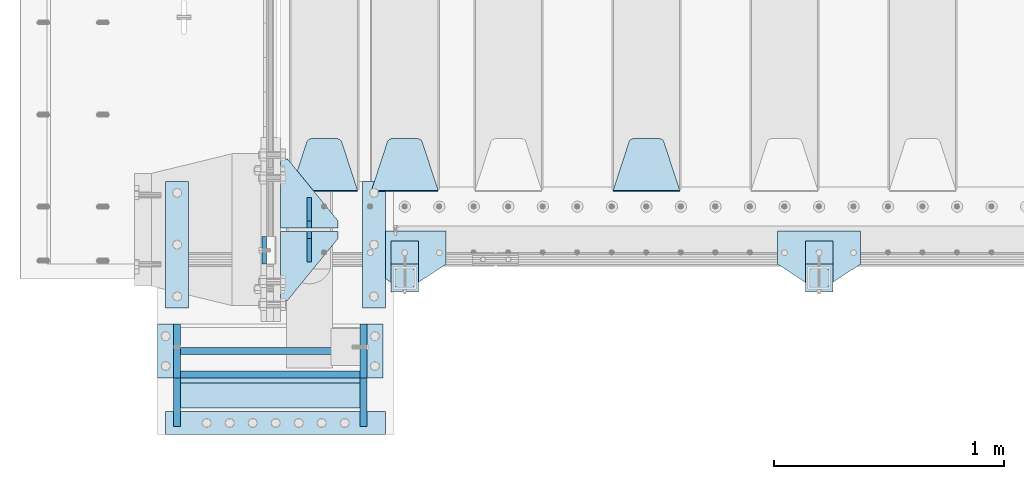
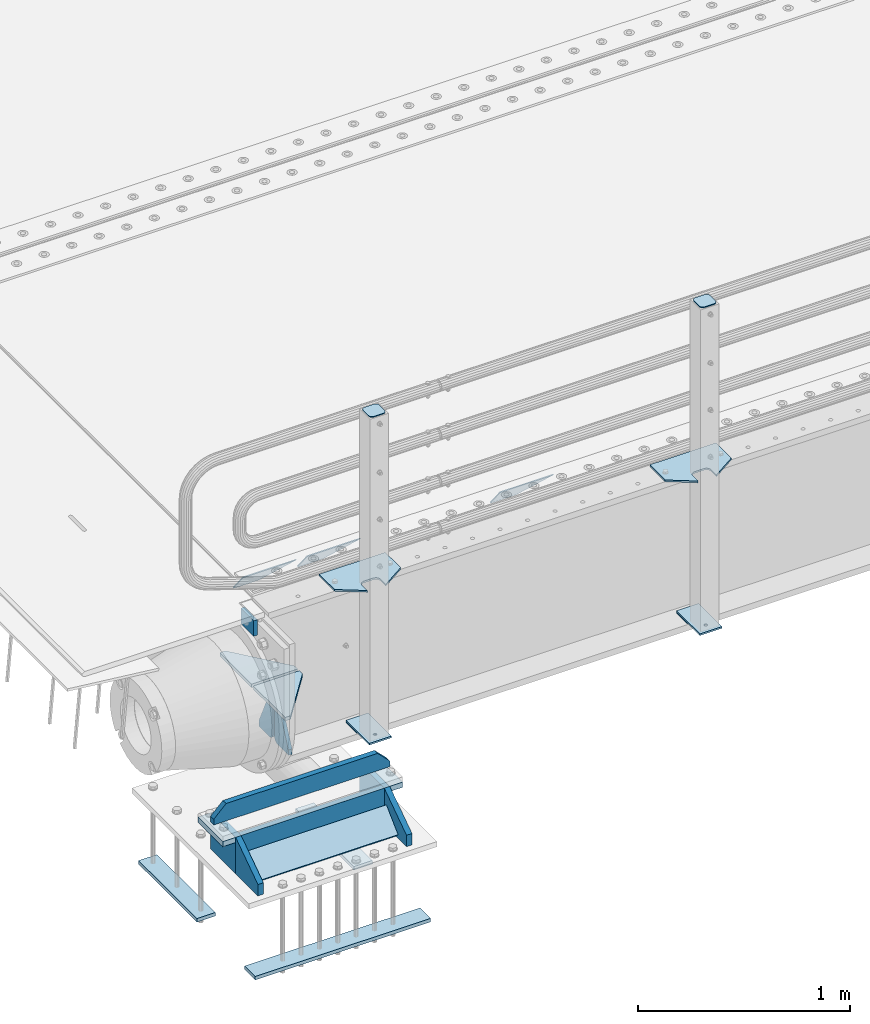
# One storey, part 214 of 270: 28 plates.
"""IFC2X3 building model written with IfcOpenShell, lengths in millimetres."""

from ifc_helpers import new_model, si_unit, frame, origin_with_axes, place, context, subcontext, project, spatial, faceted_brep, material, type_object, element, save


model = new_model("IFC2X3")

# Units and contexts
model_context = context("Model", 3, precision=1e-05, world=origin_with_axes())
body_context = subcontext(model_context, "Body", "Model", "MODEL_VIEW")
ifc_project = project(units=[si_unit("LENGTHUNIT", "METRE", prefix="MILLI"), si_unit("AREAUNIT", "SQUARE_METRE"), si_unit("VOLUMEUNIT", "CUBIC_METRE"), si_unit("MASSUNIT", "GRAM", prefix="KILO"), si_unit("TIMEUNIT", "SECOND"), si_unit("PLANEANGLEUNIT", "RADIAN"), si_unit("SOLIDANGLEUNIT", "STERADIAN"), si_unit("THERMODYNAMICTEMPERATUREUNIT", "DEGREE_CELSIUS"), si_unit("LUMINOUSINTENSITYUNIT", "LUMEN")], contexts=[model_context])

# Site, building, storey
site_placement = place(None, origin_with_axes())
site = spatial("IfcSite", under=ifc_project, at=site_placement, CompositionType="ELEMENT")
building_placement = place(site_placement, origin_with_axes())
building = spatial("IfcBuilding", under=site, at=building_placement, Name="Standard", CompositionType="ELEMENT")
storey_placement = place(building_placement, origin_with_axes())
storey = spatial("IfcBuildingStorey", under=building, at=storey_placement, Name="Undefined", CompositionType="ELEMENT", Elevation=0.0)

# Plates
ifc_material_1 = material(Name="STEEL/S355N")
plate_type_1 = type_object("IfcPlateType", PredefinedType="NOTDEFINED")
plate_1_placement = place(storey_placement, frame((-60.0000000000158, -24029.9995540187, -106.000105640918), z_axis=(0.0, -0.999999999987744, -4.95099999993769e-06), x_axis=(0.0, -4.95099997756316e-06, 0.999999999987744)))
element("IfcPlate", 1, at=plate_1_placement, inside=storey, type_object=plate_type_1, material=ifc_material_1, context=body_context, shape_type="Brep", body=[
    faceted_brep([(0.0, -10.0, 0.0), (4.30830482400779e-10, -10.0, 120.000000000004), (4.30830482400779e-10, 10.0, 120.000000000004), (0.0, 10.0, 0.0), (89.9999999999979, -10.0, 120.000000000004), (89.9999999999979, 10.0, 120.000000000004), (90.0, -10.0, 1.09139364212751e-11), (90.0, 10.0, 1.09139364212751e-11)], [[[0, 1, 2, 3]], [[1, 4, 5, 2]], [[4, 6, 7, 5]], [[6, 0, 3, 7]], [[5, 7, 3, 2]], [[6, 4, 1, 0]]]),
])
plate_type_2 = type_object("IfcPlateType", PredefinedType="NOTDEFINED")
plate_2_placement = place(storey_placement, frame((355.000000373937, -24765.3571373902, -1027.14966545662), z_axis=(-1.0, 0.0, 0.0), x_axis=(1.99999983730401e-09, 0.723355636225728, 0.690475650215467)))
element("IfcPlate", 2, at=plate_2_placement, inside=storey, type_object=plate_type_2, material=ifc_material_1, context=body_context, shape_type="Brep", body=[
    faceted_brep([(0.0, -15.0, 0.0), (2.15506588574499e-07, -15.0000000000018, 779.0), (2.15506588574499e-07, 14.9999999999982, 779.0), (0.0, 15.0, 0.0), (152.069061494802, -15.0000000000018, 779.0), (152.069061494802, 14.9999999999982, 779.0), (152.069061279297, -15.0000000000018, 0.0), (152.069061279299, 14.9999999999964, 0.0)], [[[0, 1, 2, 3]], [[1, 4, 5, 2]], [[4, 6, 7, 5]], [[6, 0, 3, 7]], [[5, 7, 3, 2]], [[6, 4, 1, 0]]]),
])
plate_type_3 = type_object("IfcPlateType", PredefinedType="NOTDEFINED")
for number, where, z_axis, x_axis in (
    (3, (366.000001649995, -24340.0000012037, -1478.0), (0.0, 1.0, 0.0), (1.0, 0.0, 0.0)),
    (4, (-488.999998350005, -24339.9999986388, -1478.0), (0.0, 1.0, 0.0), (1.0, 0.0, 0.0)),
):
    element("IfcPlate", number, at=place(storey_placement, frame(where, z_axis=z_axis, x_axis=x_axis)), inside=storey, type_object=plate_type_3, material=ifc_material_1, context=body_context, shape_type="Brep", body=[
        faceted_brep([(0.0, -10.0, 0.0), (1.00943600500614e-06, -10.0, 550.0), (1.00943600500614e-06, 10.0, 550.0), (0.0, 10.0, 0.0), (100.000000000004, -10.0, 550.0), (100.000000000004, 10.0, 550.0), (100.0, -10.0, 0.0), (100.0, 10.0, 0.0)], [[[0, 1, 2, 3]], [[1, 4, 5, 2]], [[4, 6, 7, 5]], [[6, 0, 3, 7]], [[5, 7, 3, 2]], [[6, 4, 1, 0]]]),
    ])
plate_3_placement = place(storey_placement, frame((-488.999999999989, -24889.9999986388, -1478.0), z_axis=(0.0, 1.0, 0.0), x_axis=(1.0, 0.0, 0.0)))
element("IfcPlate", 5, at=plate_3_placement, inside=storey, type_object=plate_type_3, material=ifc_material_1, context=body_context, shape_type="Brep", body=[
    faceted_brep([(0.0, -10.0, 0.0), (0.0, -10.0, 100.0), (0.0, 10.0, 100.0), (0.0, 10.0, 0.0), (955.0, -10.0, 100.0), (955.0, 10.0, 100.0), (955.0, -10.0, 0.0), (955.0, 10.0, 0.0)], [[[0, 1, 2, 3]], [[1, 4, 5, 2]], [[4, 6, 7, 5]], [[6, 0, 3, 7]], [[5, 7, 3, 2]], [[6, 4, 1, 0]]]),
])
plate_type_4 = type_object("IfcPlateType", PredefinedType="NOTDEFINED")
plate_4_placement = place(storey_placement, frame((370.000001439999, -24410.000002682, -828.000000000005), z_axis=(0.0, 0.0, -1.0), x_axis=(0.0, -1.0, 0.0)))
element("IfcPlate", 6, at=plate_4_placement, inside=storey, type_object=plate_type_4, material=ifc_material_1, context=body_context, shape_type="Brep", body=[
    faceted_brep([(0.0, -15.0, 0.0), (1.81898940354586e-12, -15.0, 210.0), (0.0, 15.0, 210.0), (0.0, 15.0, 0.0), (235.000000000002, -15.0, 210.0), (235.0, 15.0, 210.0), (235.0, -15.0, 0.0), (235.0, 15.0, 0.0)], [[[0, 1, 2, 3]], [[1, 4, 5, 2]], [[4, 6, 7, 5]], [[6, 0, 3, 7]], [[5, 7, 3, 2]], [[6, 4, 1, 0]]]),
])
for number, where, z_axis, x_axis in (
    (7, (370.00000010501, -24855.000002682, -1038.0), (0.0, 0.0, 1.0), (0.0, 1.0, 0.0)),
    (8, (-438.99999989499, -24855.000000255, -1038.0), (0.0, 0.0, 1.0), (0.0, 1.0, 0.0)),
):
    element("IfcPlate", number, at=place(storey_placement, frame(where, z_axis=z_axis, x_axis=x_axis)), inside=storey, type_object=plate_type_4, material=ifc_material_1, context=body_context, shape_type="Brep", body=[
        faceted_brep([(0.0, -15.0, 0.0), (-1.81898940354586e-12, -15.0, 66.0), (0.0, 15.0, 66.0), (0.0, 15.0, 0.0), (209.999999999998, -15.0, 210.0), (210.0, 15.0, 210.0), (209.999999999998, -15.0, 0.0), (210.0, 15.0, 0.0)], [[[0, 1, 2, 3]], [[1, 4, 5, 2]], [[4, 6, 7, 5]], [[6, 0, 3, 7]], [[5, 7, 3, 2]], [[6, 4, 1, 0]]]),
    ])
plate_5_placement = place(storey_placement, frame((-423.999999219995, -24630.0000003, -1038.0), z_axis=(1.0, 0.0, 0.0), x_axis=(0.0, 0.0, 1.0)))
element("IfcPlate", 9, at=plate_5_placement, inside=storey, type_object=plate_type_4, material=ifc_material_1, context=body_context, shape_type="Brep", body=[
    faceted_brep([(0.0, -15.0, 0.0), (2.15506588574499e-07, -15.0000000000018, 779.0), (2.15506588574499e-07, 14.9999999999982, 779.0), (0.0, 15.0, 0.0), (210.0, -15.0, 779.0), (210.0, 15.0, 779.0), (209.999999999998, -15.0, 0.0), (210.0, 15.0, 0.0)], [[[0, 1, 2, 3]], [[1, 4, 5, 2]], [[4, 6, 7, 5]], [[6, 0, 3, 7]], [[5, 7, 3, 2]], [[6, 4, 1, 0]]]),
])
plate_6_placement = place(storey_placement, frame((-438.999998560004, -24410.000000255, -828.000000000004), z_axis=(0.0, 0.0, -1.0), x_axis=(0.0, -1.0, 0.0)))
element("IfcPlate", 10, at=plate_6_placement, inside=storey, type_object=plate_type_4, material=ifc_material_1, context=body_context, shape_type="Brep", body=[
    faceted_brep([(0.0, -15.0, 0.0), (1.81898940354586e-12, -15.0, 210.0), (0.0, 15.0, 210.0), (0.0, 15.0, 0.0), (235.000000000002, -15.0, 210.0), (235.0, 15.0, 210.0), (235.0, -15.0, 0.0), (235.0, 15.0, 0.0)], [[[0, 1, 2, 3]], [[1, 4, 5, 2]], [[4, 6, 7, 5]], [[6, 0, 3, 7]], [[5, 7, 3, 2]], [[6, 4, 1, 0]]]),
])
plate_type_5 = type_object("IfcPlateType", PredefinedType="NOTDEFINED")
plate_7_placement = place(storey_placement, frame((-513.999998912499, -24527.50000003, -798.000000000004), z_axis=(0.0, 0.0, 1.0), x_axis=(1.0, 0.0, 0.0)))
element("IfcPlate", 11, at=plate_7_placement, inside=storey, type_object=plate_type_5, material=ifc_material_1, context=body_context, shape_type="Brep", body=[
    faceted_brep([(0.0, -15.0, 0.0), (-1.13686837721616e-13, -15.0, 33.0), (0.0, 15.0, 33.0), (0.0, 15.0, 0.0), (66.9999999999999, -15.0, 100.0), (66.9999999999999, 15.0, 100.0), (892.0, -15.0000000000018, 100.0), (892.0, 14.9999999999982, 100.0), (959.0, -15.0, 33.0), (959.0, 15.0, 33.0), (959.0, -15.0, 0.0), (959.0, 15.0, 0.0)], [[[0, 1, 2, 3]], [[1, 4, 5, 2]], [[4, 6, 7, 5]], [[6, 8, 9, 7]], [[8, 10, 11, 9]], [[10, 0, 3, 11]], [[5, 7, 9, 11, 3, 2]], [[10, 8, 6, 4, 1, 0]]]),
])
plate_type_6 = type_object("IfcPlateType", PredefinedType="NOTDEFINED")
for number, where, z_axis, x_axis in (
    (12, (385.000000735005, -24645.000002727, -843.000000000004), (1.0, 0.0, 0.0), (0.0, 1.0, 0.0)),
    (13, (-523.999999264995, -24645.0, -843.000000000004), (1.0, 0.0, 0.0), (0.0, 1.0, 0.0)),
):
    element("IfcPlate", number, at=place(storey_placement, frame(where, z_axis=z_axis, x_axis=x_axis)), inside=storey, type_object=plate_type_6, material=ifc_material_1, context=body_context, shape_type="Brep", body=[
        faceted_brep([(0.0, -15.0, 0.0), (0.0, -15.0, 70.0), (0.0, 15.0, 70.0), (0.0, 15.0, 0.0), (235.0, -15.0, 70.0), (235.0, 15.0, 70.0), (235.0, -15.0, 0.0), (235.0, 15.0, 0.0)], [[[0, 1, 2, 3]], [[1, 4, 5, 2]], [[4, 6, 7, 5]], [[6, 0, 3, 7]], [[5, 7, 3, 2]], [[6, 4, 1, 0]]]),
    ])
ifc_material_2 = material(Name="STEEL/S355J2")
plate_type_7 = type_object("IfcPlateType", PredefinedType="NOTDEFINED")
plate_8_placement = place(storey_placement, frame((2530.0, -24005.0, 5.00000000004911), z_axis=(0.0, -1.0, 0.0), x_axis=(-1.0, 0.0, 0.0)))
element("IfcPlate", 14, at=plate_8_placement, inside=storey, type_object=plate_type_7, material=ifc_material_2, context=body_context, shape_type="Brep", body=[
    faceted_brep([(0.0, -5.0, 0.0), (2.31396552408114e-06, -5.0, 145.0), (2.31396552408114e-06, 5.0, 145.0), (0.0, 5.0, 0.0), (130.0, -5.0, 230.0), (130.0, 5.0, 230.0), (130.0, -5.0, 180.0), (130.0, 5.0, 180.0), (130.48036798992, -5.0, 175.122741949597), (130.48036798992, 5.0, 175.122741949597), (131.903011687216, -5.0, 170.432914190873), (131.903011687216, 5.0, 170.432914190873), (134.213259692435, -5.0, 166.11074417451), (134.213259692435, 5.0, 166.11074417451), (137.322330470335, -5.0, 162.322330470337), (137.322330470335, 5.0, 162.322330470337), (141.110744174512, -5.0, 159.213259692437), (141.110744174512, 5.0, 159.213259692437), (145.432914190871, -5.0, 156.903011687218), (145.432914190871, 5.0, 156.903011687218), (150.122741949595, -5.0, 155.48036798992), (150.122741949595, 5.0, 155.48036798992), (155.0, -5.0, 155.0), (155.0, 5.0, 155.0), (205.0, -5.0, 155.0), (205.0, 5.0, 155.0), (209.877258050405, -5.0, 155.48036798992), (209.877258050405, 5.0, 155.48036798992), (214.567085809129, -5.0, 156.903011687218), (214.567085809129, 5.0, 156.903011687218), (218.889255825488, -5.0, 159.213259692437), (218.889255825488, 5.0, 159.213259692437), (222.677669529665, -5.0, 162.322330470337), (222.677669529665, 5.0, 162.322330470337), (225.786740307565, -5.0, 166.11074417451), (225.786740307565, 5.0, 166.11074417451), (228.096988312784, -5.0, 170.432914190873), (228.096988312784, 5.0, 170.432914190873), (229.51963201008, -5.0, 175.122741949597), (229.51963201008, 5.0, 175.122741949597), (230.0, -5.0, 180.0), (230.0, 5.0, 180.0), (230.0, -5.0, 230.0), (230.0, 5.0, 230.0), (360.0, -5.0, 145.0), (360.0, 5.0, 145.0), (360.0, -5.0, -7.27595761418343e-12), (360.0, 5.0, -7.27595761418343e-12)], [[[0, 1, 2, 3]], [[1, 4, 5, 2]], [[4, 6, 7, 5]], [[6, 8, 9, 7]], [[8, 10, 11, 9]], [[10, 12, 13, 11]], [[12, 14, 15, 13]], [[14, 16, 17, 15]], [[16, 18, 19, 17]], [[18, 20, 21, 19]], [[20, 22, 23, 21]], [[22, 24, 25, 23]], [[24, 26, 27, 25]], [[26, 28, 29, 27]], [[28, 30, 31, 29]], [[30, 32, 33, 31]], [[32, 34, 35, 33]], [[34, 36, 37, 35]], [[36, 38, 39, 37]], [[38, 40, 41, 39]], [[40, 42, 43, 41]], [[42, 44, 45, 43]], [[44, 46, 47, 45]], [[46, 0, 3, 47]], [[5, 7, 9, 11, 13, 15, 17, 19, 21, 23, 25, 27, 29, 31, 33, 35, 37, 39, 41, 43, 45, 47, 3, 2]], [[46, 44, 42, 40, 38, 36, 34, 32, 30, 28, 26, 24, 22, 20, 18, 16, 14, 12, 10, 8, 6, 4, 1, 0]]]),
])
plate_9_placement = place(storey_placement, frame((730.0, -24005.0, 5.00000000004911), z_axis=(0.0, -1.0, 0.0), x_axis=(-1.0, 0.0, 0.0)))
element("IfcPlate", 15, at=plate_9_placement, inside=storey, type_object=plate_type_7, material=ifc_material_2, context=body_context, shape_type="Brep", body=[
    faceted_brep([(0.0, -5.0, 0.0), (2.31396552408114e-06, -5.0, 145.0), (2.31396552408114e-06, 5.0, 145.0), (0.0, 5.0, 0.0), (130.0, -5.0, 230.0), (130.0, 5.0, 230.0), (130.0, -5.0, 180.0), (130.0, 5.0, 180.0), (130.48036798992, -5.0, 175.122741949597), (130.48036798992, 5.0, 175.122741949597), (131.903011687216, -5.0, 170.432914190873), (131.903011687216, 5.0, 170.432914190873), (134.213259692435, -5.0, 166.11074417451), (134.213259692435, 5.0, 166.11074417451), (137.322330470335, -5.0, 162.322330470337), (137.322330470335, 5.0, 162.322330470337), (141.110744174512, -5.0, 159.213259692437), (141.110744174512, 5.0, 159.213259692437), (145.432914190871, -5.0, 156.903011687218), (145.432914190871, 5.0, 156.903011687218), (150.122741949595, -5.0, 155.48036798992), (150.122741949595, 5.0, 155.48036798992), (155.0, -5.0, 155.0), (155.0, 5.0, 155.0), (205.0, -5.0, 155.0), (205.0, 5.0, 155.0), (209.877258050405, -5.0, 155.48036798992), (209.877258050405, 5.0, 155.48036798992), (214.567085809129, -5.0, 156.903011687218), (214.567085809129, 5.0, 156.903011687218), (218.889255825488, -5.0, 159.213259692437), (218.889255825488, 5.0, 159.213259692437), (222.677669529665, -5.0, 162.322330470337), (222.677669529665, 5.0, 162.322330470337), (225.786740307565, -5.0, 166.11074417451), (225.786740307565, 5.0, 166.11074417451), (228.096988312784, -5.0, 170.432914190873), (228.096988312784, 5.0, 170.432914190873), (229.51963201008, -5.0, 175.122741949597), (229.51963201008, 5.0, 175.122741949597), (230.0, -5.0, 180.0), (230.0, 5.0, 180.0), (230.0, -5.0, 230.0), (230.0, 5.0, 230.0), (360.0, -5.0, 145.0), (360.0, 5.0, 145.0), (360.0, -5.0, -7.27595761418343e-12), (360.0, 5.0, -7.27595761418343e-12)], [[[0, 1, 2, 3]], [[1, 4, 5, 2]], [[4, 6, 7, 5]], [[6, 8, 9, 7]], [[8, 10, 11, 9]], [[10, 12, 13, 11]], [[12, 14, 15, 13]], [[14, 16, 17, 15]], [[16, 18, 19, 17]], [[18, 20, 21, 19]], [[20, 22, 23, 21]], [[22, 24, 25, 23]], [[24, 26, 27, 25]], [[26, 28, 29, 27]], [[28, 30, 31, 29]], [[30, 32, 33, 31]], [[32, 34, 35, 33]], [[34, 36, 37, 35]], [[36, 38, 39, 37]], [[38, 40, 41, 39]], [[40, 42, 43, 41]], [[42, 44, 45, 43]], [[44, 46, 47, 45]], [[46, 0, 3, 47]], [[5, 7, 9, 11, 13, 15, 17, 19, 21, 23, 25, 27, 29, 31, 33, 35, 37, 39, 41, 43, 45, 47, 3, 2]], [[46, 44, 42, 40, 38, 36, 34, 32, 30, 28, 26, 24, 22, 20, 18, 16, 14, 12, 10, 8, 6, 4, 1, 0]]]),
])
plate_type_8 = type_object("IfcPlateType", PredefinedType="NOTDEFINED")
for number, where, z_axis, x_axis in (
    (16, (2409.99999999986, -24050.0000000002, -850.000000000002), (0.0, -1.0, 0.0), (-1.0, 0.0, 0.0)),
    (17, (609.999999999862, -24050.0000000002, -850.000000000002), (0.0, -1.0, 0.0), (-1.0, 0.0, 0.0)),
):
    element("IfcPlate", number, at=place(storey_placement, frame(where, z_axis=z_axis, x_axis=x_axis)), inside=storey, type_object=plate_type_8, material=ifc_material_2, context=body_context, shape_type="Brep", body=[
        faceted_brep([(53.6360389691836, -5.0, 176.363961030471), (53.6360389691836, 5.0, 176.363961030471), (59.9999999998618, 5.0, 178.999999999793), (59.9999999998618, -5.0, 178.999999999793), (66.3639610305399, 5.0, 176.363961030471), (66.3639610305399, -5.0, 176.363961030471), (68.9999999998618, 5.0, 169.999999999793), (68.9999999998618, -5.0, 169.999999999793), (66.3639610305399, 5.0, 163.636038969114), (66.3639610305399, -5.0, 163.636038969114), (59.9999999998618, 5.0, 160.999999999793), (59.9999999998618, -5.0, 160.999999999793), (53.6360389691836, 5.0, 163.636038969114), (53.6360389691836, -5.0, 163.636038969114), (50.9999999998618, 5.0, 169.999999999793), (50.9999999998618, -5.0, 169.999999999793), (120.0, -5.0, 0.0), (120.0, -5.0, 220.0), (0.0, -5.0, 220.0), (0.0, -5.0, 0.0), (0.0, 5.0, 0.0), (120.0, 5.0, 0.0), (120.0, 5.0, 220.0), (0.0, 5.0, 220.0)], [[[0, 1, 2, 3]], [[3, 2, 4, 5]], [[5, 4, 6, 7]], [[7, 6, 8, 9]], [[9, 8, 10, 11]], [[11, 10, 12, 13]], [[13, 12, 14, 15]], [[15, 14, 1, 0]], [[16, 17, 18, 19], [11, 13, 15, 0, 3, 5, 7, 9]], [[16, 19, 20, 21]], [[17, 16, 21, 22]], [[18, 17, 22, 23]], [[19, 18, 23, 20]], [[22, 21, 20, 23], [2, 1, 14, 12, 10, 8, 6, 4]]]),
    ])
plate_type_9 = type_object("IfcPlateType", PredefinedType="NOTDEFINED")
plate_10_placement = place(storey_placement, frame((2305.99999999987, -24166.0000000002, 1012.50000000001), z_axis=(0.0, -1.0, 0.0), x_axis=(1.0, 0.0, 0.0)))
element("IfcPlate", 18, at=plate_10_placement, inside=storey, type_object=plate_type_9, material=ifc_material_2, context=body_context, shape_type="Brep", body=[
    faceted_brep([(0.0, -2.5, 19.0), (0.0, -2.5, 69.0), (0.0, 2.5, 69.0), (0.0, 2.5, 19.0), (0.476369668544066, -2.5, 73.2278977451697), (0.476369668544066, 2.5, 73.2278977451697), (1.88159150985302, -2.5, 77.2437910432327), (1.88159150985302, 2.5, 77.2437910432327), (4.14520183310742, -2.5, 80.8463062353167), (4.14520183310742, 2.5, 80.8463062353167), (7.15369376468516, -2.5, 83.8547981668926), (7.15369376468516, 2.5, 83.8547981668926), (10.7562089567655, -2.5, 86.1184084901452), (10.7562089567655, 2.5, 86.1184084901452), (14.7721022548285, -2.5, 87.5236303314541), (14.7721022548285, 2.5, 87.5236303314541), (19.0, -2.5, 88.0), (19.0, 2.5, 88.0), (69.0, -2.5, 88.0), (69.0, 2.5, 88.0), (73.2278977451715, -2.5, 87.5236303314541), (73.2278977451715, 2.5, 87.5236303314541), (77.2437910432345, -2.5, 86.1184084901452), (77.2437910432345, 2.5, 86.1184084901452), (80.8463062353148, -2.5, 83.8547981668926), (80.8463062353148, 2.5, 83.8547981668926), (83.8547981668926, -2.5, 80.8463062353167), (83.8547981668926, 2.5, 80.8463062353167), (86.118408490147, -2.5, 77.2437910432345), (86.118408490147, 2.5, 77.2437910432345), (87.5236303314559, -2.5, 73.2278977451697), (87.5236303314559, 2.5, 73.2278977451697), (88.0, -2.5, 69.0), (88.0, 2.5, 69.0), (88.0, -2.5, 19.0), (88.0, 2.5, 19.0), (87.5236303314559, -2.5, 14.7721022548303), (87.5236303314559, 2.5, 14.7721022548303), (86.118408490147, -2.5, 10.7562089567673), (86.118408490147, 2.5, 10.7562089567673), (83.8547981668926, -2.5, 7.15369376468334), (83.8547981668926, 2.5, 7.15369376468334), (80.8463062353148, -2.5, 4.14520183310742), (80.8463062353148, 2.5, 4.14520183310742), (77.2437910432345, -2.5, 1.88159150985484), (77.2437910432345, 2.5, 1.88159150985484), (73.2278977451715, -2.5, 0.476369668545885), (73.2278977451715, 2.5, 0.476369668545885), (69.0, -2.5, 0.0), (69.0, 2.5, 0.0), (19.0, -2.5, 0.0), (19.0, 2.5, 0.0), (14.7721022548285, -2.5, 0.476369668545885), (14.7721022548285, 2.5, 0.476369668545885), (10.7562089567655, -2.5, 1.88159150985484), (10.7562089567655, 2.5, 1.88159150985484), (7.15369376468516, -2.5, 4.14520183310742), (7.15369376468516, 2.5, 4.14520183310742), (4.14520183310742, -2.5, 7.15369376468334), (4.14520183310742, 2.5, 7.15369376468334), (1.88159150985302, -2.5, 10.7562089567673), (1.88159150985302, 2.5, 10.7562089567673), (0.476369668544066, -2.5, 14.7721022548303), (0.476369668544066, 2.5, 14.7721022548303)], [[[0, 1, 2, 3]], [[1, 4, 5, 2]], [[4, 6, 7, 5]], [[6, 8, 9, 7]], [[8, 10, 11, 9]], [[10, 12, 13, 11]], [[12, 14, 15, 13]], [[14, 16, 17, 15]], [[16, 18, 19, 17]], [[18, 20, 21, 19]], [[20, 22, 23, 21]], [[22, 24, 25, 23]], [[24, 26, 27, 25]], [[26, 28, 29, 27]], [[28, 30, 31, 29]], [[30, 32, 33, 31]], [[32, 34, 35, 33]], [[34, 36, 37, 35]], [[36, 38, 39, 37]], [[38, 40, 41, 39]], [[40, 42, 43, 41]], [[42, 44, 45, 43]], [[44, 46, 47, 45]], [[46, 48, 49, 47]], [[48, 50, 51, 49]], [[50, 52, 53, 51]], [[52, 54, 55, 53]], [[54, 56, 57, 55]], [[56, 58, 59, 57]], [[58, 60, 61, 59]], [[60, 62, 63, 61]], [[62, 0, 3, 63]], [[5, 7, 9, 11, 13, 15, 17, 19, 21, 23, 25, 27, 29, 31, 33, 35, 37, 39, 41, 43, 45, 47, 49, 51, 53, 55, 57, 59, 61, 63, 3, 2]], [[62, 60, 58, 56, 54, 52, 50, 48, 46, 44, 42, 40, 38, 36, 34, 32, 30, 28, 26, 24, 22, 20, 18, 16, 14, 12, 10, 8, 6, 4, 1, 0]]]),
])
plate_11_placement = place(storey_placement, frame((505.999999999869, -24166.0000000002, 1012.50000000001), z_axis=(0.0, -1.0, 0.0), x_axis=(1.0, 0.0, 0.0)))
element("IfcPlate", 19, at=plate_11_placement, inside=storey, type_object=plate_type_9, material=ifc_material_2, context=body_context, shape_type="Brep", body=[
    faceted_brep([(0.0, -2.5, 19.0), (0.0, -2.5, 69.0), (0.0, 2.5, 69.0), (0.0, 2.5, 19.0), (0.476369668544066, -2.5, 73.2278977451697), (0.476369668544066, 2.5, 73.2278977451697), (1.88159150985302, -2.5, 77.2437910432327), (1.88159150985302, 2.5, 77.2437910432327), (4.14520183310742, -2.5, 80.8463062353167), (4.14520183310742, 2.5, 80.8463062353167), (7.15369376468516, -2.5, 83.8547981668926), (7.15369376468516, 2.5, 83.8547981668926), (10.7562089567655, -2.5, 86.1184084901452), (10.7562089567655, 2.5, 86.1184084901452), (14.7721022548285, -2.5, 87.5236303314541), (14.7721022548285, 2.5, 87.5236303314541), (19.0, -2.5, 88.0), (19.0, 2.5, 88.0), (69.0, -2.5, 88.0), (69.0, 2.5, 88.0), (73.2278977451715, -2.5, 87.5236303314541), (73.2278977451715, 2.5, 87.5236303314541), (77.2437910432345, -2.5, 86.1184084901452), (77.2437910432345, 2.5, 86.1184084901452), (80.8463062353148, -2.5, 83.8547981668926), (80.8463062353148, 2.5, 83.8547981668926), (83.8547981668926, -2.5, 80.8463062353167), (83.8547981668926, 2.5, 80.8463062353167), (86.118408490147, -2.5, 77.2437910432345), (86.118408490147, 2.5, 77.2437910432345), (87.5236303314559, -2.5, 73.2278977451697), (87.5236303314559, 2.5, 73.2278977451697), (88.0, -2.5, 69.0), (88.0, 2.5, 69.0), (88.0, -2.5, 19.0), (88.0, 2.5, 19.0), (87.5236303314559, -2.5, 14.7721022548303), (87.5236303314559, 2.5, 14.7721022548303), (86.118408490147, -2.5, 10.7562089567673), (86.118408490147, 2.5, 10.7562089567673), (83.8547981668926, -2.5, 7.15369376468334), (83.8547981668926, 2.5, 7.15369376468334), (80.8463062353148, -2.5, 4.14520183310742), (80.8463062353148, 2.5, 4.14520183310742), (77.2437910432345, -2.5, 1.88159150985484), (77.2437910432345, 2.5, 1.88159150985484), (73.2278977451715, -2.5, 0.476369668545885), (73.2278977451715, 2.5, 0.476369668545885), (69.0, -2.5, 0.0), (69.0, 2.5, 0.0), (19.0, -2.5, 0.0), (19.0, 2.5, 0.0), (14.7721022548285, -2.5, 0.476369668545885), (14.7721022548285, 2.5, 0.476369668545885), (10.7562089567655, -2.5, 1.88159150985484), (10.7562089567655, 2.5, 1.88159150985484), (7.15369376468516, -2.5, 4.14520183310742), (7.15369376468516, 2.5, 4.14520183310742), (4.14520183310742, -2.5, 7.15369376468334), (4.14520183310742, 2.5, 7.15369376468334), (1.88159150985302, -2.5, 10.7562089567673), (1.88159150985302, 2.5, 10.7562089567673), (0.476369668544066, -2.5, 14.7721022548303), (0.476369668544066, 2.5, 14.7721022548303)], [[[0, 1, 2, 3]], [[1, 4, 5, 2]], [[4, 6, 7, 5]], [[6, 8, 9, 7]], [[8, 10, 11, 9]], [[10, 12, 13, 11]], [[12, 14, 15, 13]], [[14, 16, 17, 15]], [[16, 18, 19, 17]], [[18, 20, 21, 19]], [[20, 22, 23, 21]], [[22, 24, 25, 23]], [[24, 26, 27, 25]], [[26, 28, 29, 27]], [[28, 30, 31, 29]], [[30, 32, 33, 31]], [[32, 34, 35, 33]], [[34, 36, 37, 35]], [[36, 38, 39, 37]], [[38, 40, 41, 39]], [[40, 42, 43, 41]], [[42, 44, 45, 43]], [[44, 46, 47, 45]], [[46, 48, 49, 47]], [[48, 50, 51, 49]], [[50, 52, 53, 51]], [[52, 54, 55, 53]], [[54, 56, 57, 55]], [[56, 58, 59, 57]], [[58, 60, 61, 59]], [[60, 62, 63, 61]], [[62, 0, 3, 63]], [[5, 7, 9, 11, 13, 15, 17, 19, 21, 23, 25, 27, 29, 31, 33, 35, 37, 39, 41, 43, 45, 47, 49, 51, 53, 55, 57, 59, 61, 63, 3, 2]], [[62, 60, 58, 56, 54, 52, 50, 48, 46, 44, 42, 40, 38, 36, 34, 32, 30, 28, 26, 24, 22, 20, 18, 16, 14, 12, 10, 8, 6, 4, 1, 0]]]),
])
plate_type_10 = type_object("IfcPlateType", PredefinedType="NOTDEFINED")
for number, where, z_axis, x_axis in (
    (20, (2409.99999999986, -24050.0000000002, -857.500000000002), (0.0, -1.0, 0.0), (-1.0, 0.0, 0.0)),
    (21, (609.999999999862, -24050.0000000002, -857.500000000002), (0.0, -1.0, 0.0), (-1.0, 0.0, 0.0)),
):
    element("IfcPlate", number, at=place(storey_placement, frame(where, z_axis=z_axis, x_axis=x_axis)), inside=storey, type_object=plate_type_10, material=ifc_material_2, context=body_context, shape_type="Brep", body=[
        faceted_brep([(0.0, -2.5, 0.0), (0.0, -2.5, 100.0), (0.0, 2.5, 100.0), (0.0, 2.5, 0.0), (120.0, -2.5, 100.0), (120.0, 2.5, 100.0), (120.0, -2.5, 0.0), (120.0, 2.5, 0.0)], [[[0, 1, 2, 3]], [[1, 4, 5, 2]], [[4, 6, 7, 5]], [[6, 0, 3, 7]], [[5, 7, 3, 2]], [[6, 4, 1, 0]]]),
    ])
plate_type_11 = type_object("IfcPlateType", PredefinedType="NOTDEFINED")
plate_12_placement = place(storey_placement, frame((1745.0, -23831.767766953, -1.76776695296758), z_axis=(0.0, 0.707106781186547, -0.707106781186548), x_axis=(-1.0, 0.0, 0.0)))
element("IfcPlate", 22, at=plate_12_placement, inside=storey, type_object=plate_type_11, material=ifc_material_1, context=body_context, shape_type="Brep", body=[
    faceted_brep([(0.0, -2.5, 0.0), (69.345504679477, -2.5, 300.171731424831), (69.345504679477, 2.5, 300.171731424831), (0.0, 2.5, 0.0), (70.9274061199576, -2.5, 304.8974424154), (70.9274061199576, 2.5, 304.8974424154), (73.3818627772307, -2.49999999999818, 309.234538108527), (73.3818627772307, 2.50000000000182, 309.234538108527), (76.6187032999551, -2.5, 313.023683126103), (76.6187032999551, 2.5, 313.023683126103), (80.5190132704993, -2.5, 316.125672595372), (80.5190132704993, 2.50000000000182, 316.125672595372), (84.9395038596849, -2.49999999999818, 318.426546230476), (84.9395038596849, 2.5, 318.426546230476), (89.7177759439219, -2.49999999999818, 319.841774983275), (89.7177759439219, 2.50000000000182, 319.841774983275), (94.678286292652, -2.5, 320.319366455078), (94.678286292652, 2.5, 320.319366455078), (195.321713707348, -2.5, 320.319366455078), (195.321713707348, 2.5, 320.319366455078), (200.282224056078, -2.49999999999818, 319.841774983275), (200.282224056078, 2.50000000000182, 319.841774983275), (205.060496140315, -2.5, 318.426546230476), (205.060496140315, 2.5, 318.426546230476), (209.480986729501, -2.5, 316.12567259537), (209.480986729501, 2.50000000000182, 316.12567259537), (213.381296700045, -2.5, 313.023683126103), (213.381296700045, 2.5, 313.023683126103), (216.618137222769, -2.49999999999818, 309.234538108525), (216.618137222769, 2.50000000000182, 309.234538108527), (219.072593880042, -2.49999999999818, 304.897442415398), (219.072593880042, 2.50000000000182, 304.897442415397), (220.654495320523, -2.5, 300.171731424831), (220.654495320523, 2.5, 300.171731424831), (290.0, -2.49999999999818, 0.0), (290.0, 2.5, 0.0)], [[[0, 1, 2, 3]], [[1, 4, 5, 2]], [[4, 6, 7, 5]], [[6, 8, 9, 7]], [[8, 10, 11, 9]], [[10, 12, 13, 11]], [[12, 14, 15, 13]], [[14, 16, 17, 15]], [[16, 18, 19, 17]], [[18, 20, 21, 19]], [[20, 22, 23, 21]], [[22, 24, 25, 23]], [[24, 26, 27, 25]], [[26, 28, 29, 27]], [[28, 30, 31, 29]], [[30, 32, 33, 31]], [[32, 34, 35, 33]], [[34, 0, 3, 35]], [[5, 7, 9, 11, 13, 15, 17, 19, 21, 23, 25, 27, 29, 31, 33, 35, 3, 2]], [[34, 32, 30, 28, 26, 24, 22, 20, 18, 16, 14, 12, 10, 8, 6, 4, 1, 0]]]),
])
plate_13_placement = place(storey_placement, frame((695.0, -23831.767766953, -1.76776695296758), z_axis=(0.0, 0.707106781186547, -0.707106781186548), x_axis=(-1.0, 0.0, 0.0)))
element("IfcPlate", 23, at=plate_13_placement, inside=storey, type_object=plate_type_11, material=ifc_material_1, context=body_context, shape_type="Brep", body=[
    faceted_brep([(0.0, -2.5, 0.0), (69.345504679477, -2.5, 300.171731424831), (69.345504679477, 2.5, 300.171731424831), (0.0, 2.5, 0.0), (70.9274061199576, -2.5, 304.8974424154), (70.9274061199576, 2.5, 304.8974424154), (73.3818627772307, -2.49999999999818, 309.234538108527), (73.3818627772307, 2.50000000000182, 309.234538108527), (76.6187032999551, -2.5, 313.023683126103), (76.6187032999551, 2.5, 313.023683126103), (80.5190132704993, -2.5, 316.125672595372), (80.5190132704993, 2.50000000000182, 316.125672595372), (84.9395038596849, -2.49999999999818, 318.426546230476), (84.9395038596849, 2.5, 318.426546230476), (89.7177759439219, -2.49999999999818, 319.841774983275), (89.7177759439219, 2.50000000000182, 319.841774983275), (94.678286292652, -2.5, 320.319366455078), (94.678286292652, 2.5, 320.319366455078), (195.321713707348, -2.5, 320.319366455078), (195.321713707348, 2.5, 320.319366455078), (200.282224056078, -2.49999999999818, 319.841774983275), (200.282224056078, 2.50000000000182, 319.841774983275), (205.060496140315, -2.5, 318.426546230476), (205.060496140315, 2.5, 318.426546230476), (209.480986729501, -2.5, 316.12567259537), (209.480986729501, 2.50000000000182, 316.12567259537), (213.381296700045, -2.5, 313.023683126103), (213.381296700045, 2.5, 313.023683126103), (216.618137222769, -2.49999999999818, 309.234538108525), (216.618137222769, 2.50000000000182, 309.234538108527), (219.072593880042, -2.49999999999818, 304.897442415398), (219.072593880042, 2.50000000000182, 304.897442415397), (220.654495320523, -2.5, 300.171731424831), (220.654495320523, 2.5, 300.171731424831), (290.0, -2.49999999999818, 0.0), (290.0, 2.5, 0.0)], [[[0, 1, 2, 3]], [[1, 4, 5, 2]], [[4, 6, 7, 5]], [[6, 8, 9, 7]], [[8, 10, 11, 9]], [[10, 12, 13, 11]], [[12, 14, 15, 13]], [[14, 16, 17, 15]], [[16, 18, 19, 17]], [[18, 20, 21, 19]], [[20, 22, 23, 21]], [[22, 24, 25, 23]], [[24, 26, 27, 25]], [[26, 28, 29, 27]], [[28, 30, 31, 29]], [[30, 32, 33, 31]], [[32, 34, 35, 33]], [[34, 0, 3, 35]], [[5, 7, 9, 11, 13, 15, 17, 19, 21, 23, 25, 27, 29, 31, 33, 35, 3, 2]], [[34, 32, 30, 28, 26, 24, 22, 20, 18, 16, 14, 12, 10, 8, 6, 4, 1, 0]]]),
])
plate_14_placement = place(storey_placement, frame((345.0, -23831.767766953, -1.76776695296758), z_axis=(0.0, 0.707106781186547, -0.707106781186548), x_axis=(-1.0, 0.0, 0.0)))
element("IfcPlate", 24, at=plate_14_placement, inside=storey, type_object=plate_type_11, material=ifc_material_1, context=body_context, shape_type="Brep", body=[
    faceted_brep([(0.0, -2.5, 0.0), (69.345504679477, -2.5, 300.171731424831), (69.345504679477, 2.5, 300.171731424831), (0.0, 2.5, 0.0), (70.9274061199576, -2.5, 304.8974424154), (70.9274061199576, 2.5, 304.8974424154), (73.3818627772307, -2.49999999999818, 309.234538108527), (73.3818627772307, 2.50000000000182, 309.234538108527), (76.6187032999551, -2.5, 313.023683126103), (76.6187032999551, 2.5, 313.023683126103), (80.5190132704993, -2.5, 316.125672595372), (80.5190132704993, 2.50000000000182, 316.125672595372), (84.9395038596849, -2.49999999999818, 318.426546230476), (84.9395038596849, 2.5, 318.426546230476), (89.7177759439219, -2.49999999999818, 319.841774983275), (89.7177759439219, 2.50000000000182, 319.841774983275), (94.678286292652, -2.5, 320.319366455078), (94.678286292652, 2.5, 320.319366455078), (195.321713707348, -2.5, 320.319366455078), (195.321713707348, 2.5, 320.319366455078), (200.282224056078, -2.49999999999818, 319.841774983275), (200.282224056078, 2.50000000000182, 319.841774983275), (205.060496140315, -2.5, 318.426546230476), (205.060496140315, 2.5, 318.426546230476), (209.480986729501, -2.5, 316.12567259537), (209.480986729501, 2.50000000000182, 316.12567259537), (213.381296700045, -2.5, 313.023683126103), (213.381296700045, 2.5, 313.023683126103), (216.618137222769, -2.49999999999818, 309.234538108525), (216.618137222769, 2.50000000000182, 309.234538108527), (219.072593880042, -2.49999999999818, 304.897442415398), (219.072593880042, 2.50000000000182, 304.897442415397), (220.654495320523, -2.5, 300.171731424831), (220.654495320523, 2.5, 300.171731424831), (290.0, -2.49999999999818, 0.0), (290.0, 2.5, 0.0)], [[[0, 1, 2, 3]], [[1, 4, 5, 2]], [[4, 6, 7, 5]], [[6, 8, 9, 7]], [[8, 10, 11, 9]], [[10, 12, 13, 11]], [[12, 14, 15, 13]], [[14, 16, 17, 15]], [[16, 18, 19, 17]], [[18, 20, 21, 19]], [[20, 22, 23, 21]], [[22, 24, 25, 23]], [[24, 26, 27, 25]], [[26, 28, 29, 27]], [[28, 30, 31, 29]], [[30, 32, 33, 31]], [[32, 34, 35, 33]], [[34, 0, 3, 35]], [[5, 7, 9, 11, 13, 15, 17, 19, 21, 23, 25, 27, 29, 31, 33, 35, 3, 2]], [[34, 32, 30, 28, 26, 24, 22, 20, 18, 16, 14, 12, 10, 8, 6, 4, 1, 0]]]),
])
plate_type_12 = type_object("IfcPlateType", PredefinedType="NOTDEFINED")
for number, where, z_axis, x_axis in (
    (25, (259.999999999996, -23992.0, -515.0), (0.0, 1.0, 0.0), (-1.0, 0.0, 0.0)),
    (26, (259.999999999996, -24008.0, -515.0), (0.0, -1.0, 0.0), (-1.0, 0.0, 0.0)),
):
    element("IfcPlate", number, at=place(storey_placement, frame(where, z_axis=z_axis, x_axis=x_axis)), inside=storey, type_object=plate_type_12, material=ifc_material_1, context=body_context, shape_type="Brep", body=[
        faceted_brep([(0.0, -10.0, 0.0), (0.0, -10.0, 30.0), (0.0, 10.0, 30.0), (0.0, 10.0, 0.0), (220.0, -10.0, 300.0), (220.0, 10.0, 300.0), (250.0, -10.0, 300.0), (250.0, 10.0, 300.0), (250.0, -10.0, 0.0), (250.0, 10.0, 0.0)], [[[0, 1, 2, 3]], [[1, 4, 5, 2]], [[4, 6, 7, 5]], [[6, 8, 9, 7]], [[8, 0, 3, 9]], [[5, 7, 9, 3, 2]], [[8, 6, 4, 1, 0]]]),
    ])
plate_type_13 = type_object("IfcPlateType", PredefinedType="NOTDEFINED")
for number, where, z_axis, x_axis in (
    (27, (135.0, -23860.0, -865.0), (0.0, 0.0, 1.0), (0.0, -1.0, 0.0)),
    (28, (135.0, -24140.0, -865.0), (0.0, 0.0, 1.0), (0.0, 1.0, 0.0)),
):
    element("IfcPlate", number, at=place(storey_placement, frame(where, z_axis=z_axis, x_axis=x_axis)), inside=storey, type_object=plate_type_13, material=ifc_material_1, context=body_context, shape_type="Brep", body=[
        faceted_brep([(0.0, -10.0, 0.0), (0.0, -10.0, 30.0), (0.0, 10.0, 30.0), (0.0, 10.0, 0.0), (102.0, -10.0, 250.0), (102.0, 10.0, 250.0), (132.0, -10.0, 250.0), (132.0, 10.0, 250.0), (132.0, -10.0, 30.0), (132.0, 10.0, 30.0), (131.544232590368, -10.0, 24.790554669992), (131.544232590368, 10.0, 24.790554669992), (130.190778623579, -10.0, 19.7393957002299), (130.190778623579, 10.0, 19.7393957002299), (127.980762113533, -10.0, 15.0), (127.980762113533, 10.0, 15.0), (124.98133329357, -10.0, 10.7163717094038), (124.98133329357, 10.0, 10.7163717094038), (121.283628290596, -10.0, 7.01866670643062), (121.283628290596, 10.0, 7.01866670643062), (117.0, -10.0, 4.01923788646684), (117.0, 10.0, 4.01923788646684), (112.260604299769, -10.0, 1.80922137642278), (112.260604299769, 10.0, 1.80922137642278), (107.209445330009, -10.0, 0.455767409633722), (107.209445330009, 10.0, 0.455767409633722), (102.0, -10.0, 0.0), (102.0, 10.0, 0.0)], [[[0, 1, 2, 3]], [[1, 4, 5, 2]], [[4, 6, 7, 5]], [[6, 8, 9, 7]], [[8, 10, 11, 9]], [[10, 12, 13, 11]], [[12, 14, 15, 13]], [[14, 16, 17, 15]], [[16, 18, 19, 17]], [[18, 20, 21, 19]], [[20, 22, 23, 21]], [[22, 24, 25, 23]], [[24, 26, 27, 25]], [[26, 0, 3, 27]], [[5, 7, 9, 11, 13, 15, 17, 19, 21, 23, 25, 27, 3, 2]], [[26, 24, 22, 20, 18, 16, 14, 12, 10, 8, 6, 4, 1, 0]]]),
    ])

save(model, "model.ifc")
